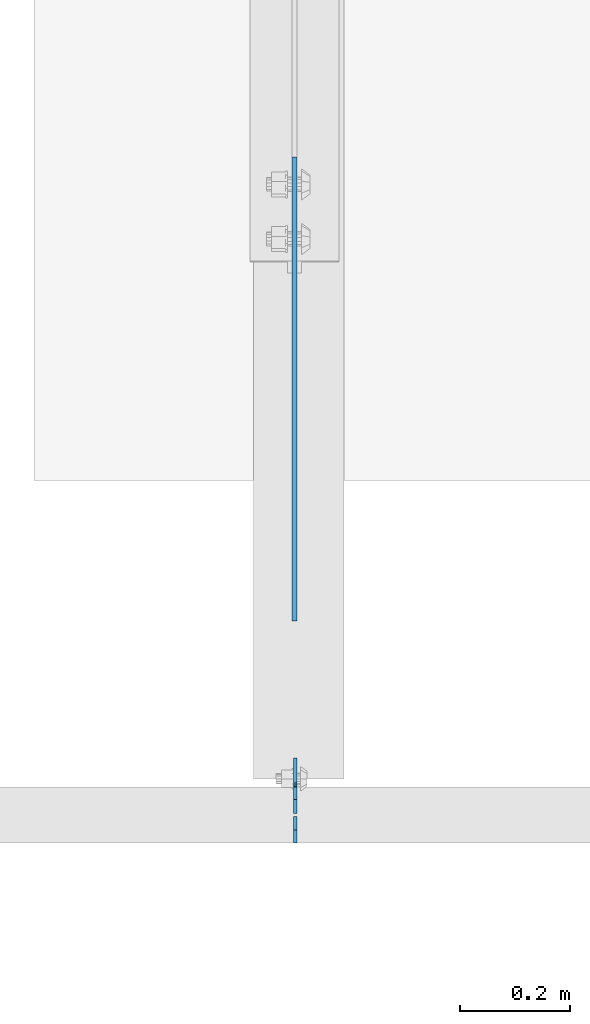
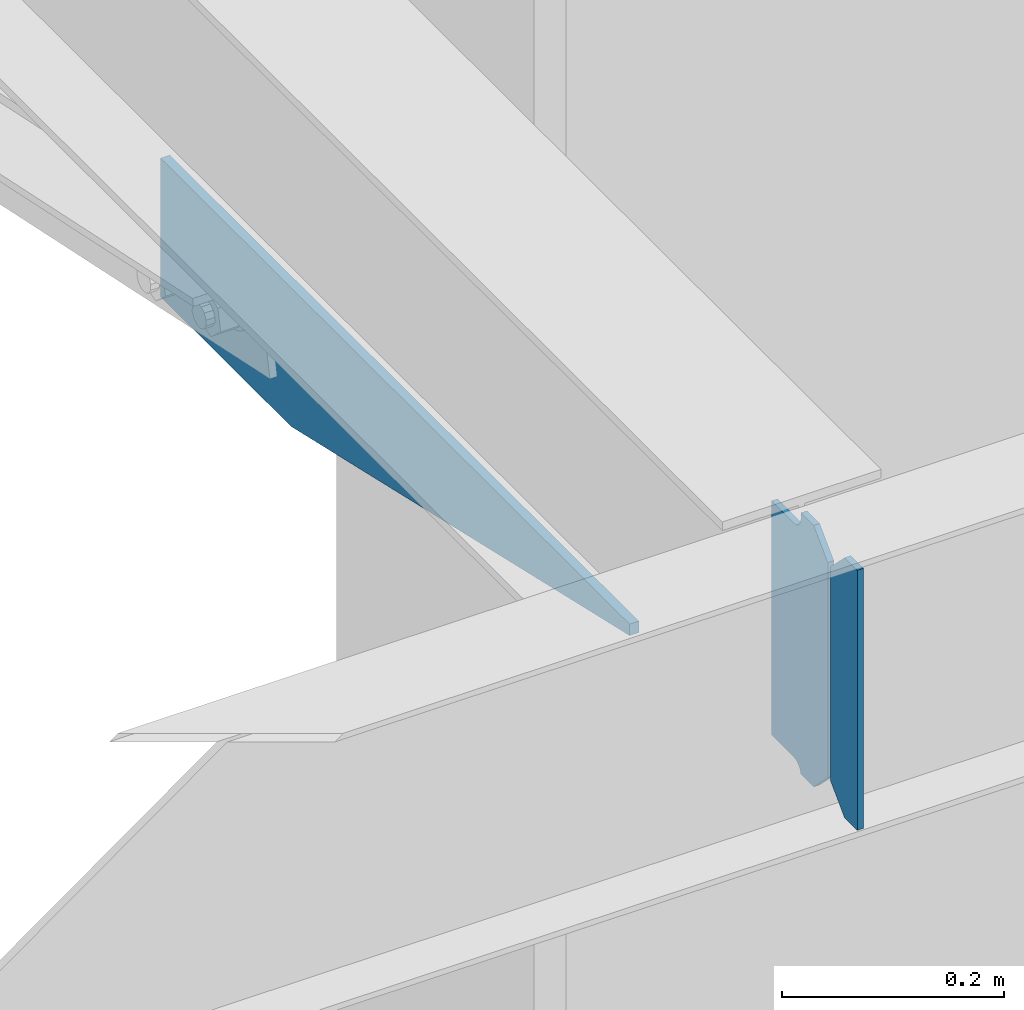
# One storey, part 1604 of 1763: 3 plates, 2 elements without a shape of their own.
"""IFC2X3 building model written with IfcOpenShell, lengths in millimetres."""

import ifcopenshell
import ifcopenshell.guid

model = None  # the IFC model being written
_history = None  # IfcOwnerHistory: only IFC2X3 demands one
_inside = {}  # id of a spatial element -> (the spatial element, [elements in it])
_under = {}  # id of a project, library or spatial element -> (it, [spatial elements below it])
_declared = {}  # id of a project -> (the project, [libraries it declares])
_typed = {}  # id of a type object -> (the type object, [elements of that type])
_made_of = {}  # id of a material, layer set ... -> (it, [elements and type objects made of it])


def new_model(schema):
    """Start an empty IFC model of exactly this schema.

    Asked for "IFC4X3", IfcOpenShell would pick the latest addendum, in which some entities
    have other attributes; the version numbers below select the first issue.
    IFC2X3 requires an IfcOwnerHistory on every rooted entity: one is made here for all.
    """
    global model, _history
    if schema == "IFC4X3":
        model = ifcopenshell.file(schema_version=(4, 3, 0, 0))
    else:
        model = ifcopenshell.file(schema=schema)
    _inside.clear()
    _under.clear()
    _declared.clear()
    _typed.clear()
    _made_of.clear()
    _history = None
    if model.schema == "IFC2X3":
        org = make("IfcOrganization", Name="unknown")
        user = make(
            "IfcPersonAndOrganization",
            ThePerson=make("IfcPerson", FamilyName="unknown"),
            TheOrganization=org,
        )
        app = make(
            "IfcApplication",
            ApplicationDeveloper=org,
            Version="unknown",
            ApplicationFullName="unknown",
            ApplicationIdentifier="unknown",
        )
        _history = make(
            "IfcOwnerHistory",
            OwningUser=user,
            OwningApplication=app,
            ChangeAction="ADDED",
            CreationDate=0,
        )
    return model


def make(cls, **values):
    """One entity of the class cls with the attributes given. An attribute that is None is left unset."""
    return model.create_entity(
        cls, **{name: value for name, value in values.items() if value is not None}
    )


def rooted(cls, **values):
    """An entity with a GlobalId (a new one), such as an element, a storey or a relation."""
    return make(cls, GlobalId=ifcopenshell.guid.new(), OwnerHistory=_history, **values)


def si_unit(unit_type, name, prefix=None):
    """IfcSIUnit, for example si_unit("LENGTHUNIT", "METRE", prefix="MILLI")."""
    return make("IfcSIUnit", UnitType=unit_type, Prefix=prefix, Name=name)


def assignment(units):
    """IfcUnitAssignment: the units of a project."""
    return None if units is None else make("IfcUnitAssignment", Units=units)


def point(xyz):
    """IfcCartesianPoint."""
    return None if xyz is None else make("IfcCartesianPoint", Coordinates=xyz)


def direction(xyz):
    """IfcDirection."""
    return None if xyz is None else make("IfcDirection", DirectionRatios=xyz)


def frame(location, z_axis=None, x_axis=None):
    """IfcAxis2Placement3D, a coordinate frame: its origin and axes. An axis left out is left unset."""
    return make(
        "IfcAxis2Placement3D",
        Location=point(location),
        Axis=direction(z_axis),
        RefDirection=direction(x_axis),
    )


def origin_with_axes():
    """The frame at (0, 0, 0) with the z axis (0, 0, 1) and the x axis (1, 0, 0) written out."""
    return frame((0.0, 0.0, 0.0), z_axis=(0.0, 0.0, 1.0), x_axis=(1.0, 0.0, 0.0))


def place(relative_to, where):
    """IfcLocalPlacement: puts the frame where relative to a parent placement (None: the world)."""
    return make(
        "IfcLocalPlacement", PlacementRelTo=relative_to, RelativePlacement=where
    )


def context(
    kind, dimensions, precision=None, world=None, true_north=None, identifier=None
):
    """IfcGeometricRepresentationContext, for example the 3D "Model" context."""
    return make(
        "IfcGeometricRepresentationContext",
        ContextIdentifier=identifier,
        ContextType=kind,
        CoordinateSpaceDimension=dimensions,
        Precision=precision,
        WorldCoordinateSystem=world,
        TrueNorth=true_north,
    )


def subcontext(parent, identifier, kind, view, scale=None):
    """IfcGeometricRepresentationSubContext, for example "Body" below "Model"."""
    return make(
        "IfcGeometricRepresentationSubContext",
        ContextIdentifier=identifier,
        ContextType=kind,
        ParentContext=parent,
        TargetScale=scale,
        TargetView=view,
    )


def project(units=None, contexts=None):
    """IfcProject with its units and contexts."""
    return rooted(
        "IfcProject",
        Name="project",
        RepresentationContexts=contexts,
        UnitsInContext=assignment(units),
    )


def spatial(cls, under=None, at=None, **own):
    """A site, building, storey or space (cls), placed at a placement, below another one or the project."""
    s = rooted(cls, ObjectPlacement=at, **own)
    if under is not None:
        _under.setdefault(under.id(), (under, []))[1].append(s)
    return s


def faces_of(points, faces, orient=None, outer=None):
    """IfcFace entities. A face is a list of loops; a loop is a list of indices into points, from 0.

    orient and outer hold one flag for each loop. By default every Orientation is true, the
    first loop of a face is its IfcFaceOuterBound and the others are IfcFaceBound.
    """
    made = []
    for i, loops in enumerate(faces):
        bounds = []
        for j, loop in enumerate(loops):
            is_outer = j == 0 if outer is None else outer[i][j]
            bounds.append(
                make(
                    "IfcFaceOuterBound" if is_outer else "IfcFaceBound",
                    Bound=make("IfcPolyLoop", Polygon=[points[k] for k in loop]),
                    Orientation=True if orient is None else orient[i][j],
                )
            )
        made.append(make("IfcFace", Bounds=bounds))
    return made


def faceted_brep(points, faces, orient=None, outer=None, voids=None):
    """IfcFacetedBrep: a solid bounded by flat faces; with voids (closed shells), ...WithVoids."""
    shared = [point(p) for p in points]
    hull = make("IfcClosedShell", CfsFaces=faces_of(shared, faces, orient, outer))
    if voids is None:
        return make("IfcFacetedBrep", Outer=hull)
    return make(
        "IfcFacetedBrepWithVoids",
        Outer=hull,
        Voids=[
            make(cls, CfsFaces=faces_of(shared, fs, o, b)) for cls, fs, o, b in voids
        ],
    )


def shape(context_of_items, identifier, shape_type, items):
    """IfcShapeRepresentation: the items that make up one representation, for example the "Body"."""
    return make(
        "IfcShapeRepresentation",
        ContextOfItems=context_of_items,
        RepresentationIdentifier=identifier,
        RepresentationType=shape_type,
        Items=items,
    )


def material(Name=None, Category=None):
    """IfcMaterial."""
    return make("IfcMaterial", Name=Name, Category=Category)


def made_of(thing, what):
    """Note that an element or type object is made of a material, layer set ...; save() writes the relation."""
    if what is not None:
        _made_of.setdefault(what.id(), (what, []))[1].append(thing)
    return thing


def type_object(cls, material=None, **own):
    """A type object (cls), such as IfcWallType, which elements share."""
    return made_of(rooted(cls, **own), material)


def element(
    cls,
    number,
    at=None,
    inside=None,
    cuts=None,
    type_object=None,
    material=None,
    context=None,
    identifier="Body",
    shape_type=None,
    held_by="IfcProductDefinitionShape",
    body=None,
    shapes=None,
    **own,
):
    """One element of the class cls, such as IfcWall. Its Tag is "e" and its number.

    at: its placement. inside: the storey or other place that contains it. cuts: it is an
    opening in that element (IfcRelVoidsElement). A single representation is given by context,
    identifier, shape_type and body (its items); several are given by shapes. held_by: the class
    of the entity that holds the representations. save() writes the other relations.
    """
    e = rooted(cls, Tag="e%d" % number, ObjectPlacement=at, **own)
    if body is not None:
        shapes = [shape(context, identifier, shape_type, body)]
    if shapes is not None:
        e.Representation = make(held_by, Representations=shapes)
    if inside is not None:
        _inside.setdefault(inside.id(), (inside, []))[1].append(e)
    if cuts is not None:
        rooted(
            "IfcRelVoidsElement", RelatingBuildingElement=cuts, RelatedOpeningElement=e
        )
    if type_object is not None:
        _typed.setdefault(type_object.id(), (type_object, []))[1].append(e)
    return made_of(e, material)


def aggregate(whole, parts):
    """IfcRelAggregates: a whole, such as a stair, and the parts it consists of."""
    return rooted("IfcRelAggregates", RelatingObject=whole, RelatedObjects=parts)


def save(model, path):
    """Write the relations noted so far, then the file.

    IfcRelAggregates (storeys below a building ...), IfcRelContainedInSpatialStructure (elements
    in a storey), IfcRelDefinesByType, IfcRelAssociatesMaterial and IfcRelDeclares: one each for
    every whole, place, type object, material and project.
    """
    for whole, parts in _under.values():
        aggregate(whole, parts)
    for where, things in _inside.values():
        rooted(
            "IfcRelContainedInSpatialStructure",
            RelatedElements=things,
            RelatingStructure=where,
        )
    for kind, things in _typed.values():
        rooted("IfcRelDefinesByType", RelatedObjects=things, RelatingType=kind)
    for what, things in _made_of.values():
        rooted("IfcRelAssociatesMaterial", RelatedObjects=things, RelatingMaterial=what)
    for by, libraries in _declared.values():
        rooted("IfcRelDeclares", RelatingContext=by, RelatedDefinitions=libraries)
    model.write(path)


model = new_model("IFC2X3")

# Units and contexts
model_context = context("Model", 3, precision=1e-05, world=origin_with_axes())
body_context = subcontext(model_context, "Body", "Model", "MODEL_VIEW")
ifc_project = project(units=[si_unit("LENGTHUNIT", "METRE", prefix="MILLI"), si_unit("AREAUNIT", "SQUARE_METRE"), si_unit("VOLUMEUNIT", "CUBIC_METRE"), si_unit("MASSUNIT", "GRAM", prefix="KILO"), si_unit("TIMEUNIT", "SECOND"), si_unit("PLANEANGLEUNIT", "RADIAN"), si_unit("SOLIDANGLEUNIT", "STERADIAN"), si_unit("THERMODYNAMICTEMPERATUREUNIT", "DEGREE_CELSIUS"), si_unit("LUMINOUSINTENSITYUNIT", "LUMEN")], contexts=[model_context])

# Site, building, storey
site_placement = place(None, origin_with_axes())
site = spatial("IfcSite", under=ifc_project, at=site_placement, CompositionType="ELEMENT")
building_placement = place(site_placement, origin_with_axes())
building = spatial("IfcBuilding", under=site, at=building_placement, Name="Undefined", CompositionType="ELEMENT")
storey_placement = place(building_placement, origin_with_axes())
storey = spatial("IfcBuildingStorey", under=building, at=storey_placement, Name="Undefined", CompositionType="ELEMENT", Elevation=0.0)

# Assembly, plate
assembly_1_placement = place(storey_placement, origin_with_axes())
assembly_1 = element("IfcElementAssembly", 1, at=assembly_1_placement, inside=storey, Name="BEAM", AssemblyPlace="NOTDEFINED", PredefinedType="RIGID_FRAME")
ifc_material = material(Name="STEEL/A36")
plate_type_1 = type_object("IfcPlateType", PredefinedType="NOTDEFINED")
plate_1_placement = place(assembly_1_placement, frame((-73845.1747736984, 50880.5595338104, 4883.15), z_axis=(0.0, -1.0, 0.0), x_axis=(0.0, 0.0, -1.0)))
plate_1 = element("IfcPlate", 2, at=plate_1_placement, type_object=plate_type_1, material=ifc_material, Name="PLATE", context=body_context, shape_type="Brep", body=[
    faceted_brep([(0.0, -4.76249999999982, 0.0), (0.0, -4.76249999999709, 844.603210449219), (0.0, 4.76249999999709, 844.603210449219), (0.0, 4.76249999999982, 0.0), (12.6999998092651, -4.76249999999709, 844.603210449219), (12.6999998092651, 4.76249999999709, 844.603210449219), (152.399993896484, -4.76249999999709, 235.00325012207), (152.399993896484, 4.76249999999709, 235.00325012207), (152.400009155272, -4.76249999948777, 5.45696821063757e-12), (152.400009155273, 4.76250000051368, 3.63797880709171e-12)], [[[0, 1, 2, 3]], [[1, 4, 5, 2]], [[4, 6, 7, 5]], [[6, 8, 9, 7]], [[8, 0, 3, 9]], [[5, 7, 9, 3, 2]], [[8, 6, 4, 1, 0]]]),
])
aggregate(assembly_1, [plate_1])

# Assembly, plates
assembly_2_placement = place(storey_placement, origin_with_axes())
assembly_2 = element("IfcElementAssembly", 3, at=assembly_2_placement, inside=storey, Name="BEAM", AssemblyPlace="NOTDEFINED", PredefinedType="RIGID_FRAME")
plate_type_2 = type_object("IfcPlateType", PredefinedType="NOTDEFINED")
plate_2_placement = place(assembly_2_placement, frame((-73843.587273746, 49684.78125, 4900.6125), z_axis=(0.0, 0.0, 1.0), x_axis=(0.0, 1.0, 0.0)))
plate_2 = element("IfcPlate", 4, at=plate_2_placement, type_object=plate_type_2, material=ifc_material, Name="PLATE", context=body_context, shape_type="Brep", body=[
    faceted_brep([(48.7345236062902, -3.17500000000291, 0.0), (48.7345236062902, 3.17500000000291, 0.0), (49.3854800386544, 3.17500000000291, 3.27257877585271), (49.3854800386544, -3.17500000000291, 3.27257877585271), (52.1384942519726, 3.17500000000291, 7.39275539271512), (52.1384942519726, -3.17500000000291, 7.39275539271512), (56.2586711318072, 3.17500000000291, 10.1457692124714), (56.2586711318072, -3.17500000000291, 10.1457692124714), (61.1187510223899, 3.17500000000291, 11.1124987868779), (61.1187510223899, -3.17500000000291, 11.1124987868779), (101.599998474121, -3.17500000000291, 11.1124949200548), (101.599998474121, 3.17500000000291, 11.1124949200548), (25.3999996184939, -3.17499999996653, 1.2732925824821e-11), (0.0, -3.17499999987194, 25.4000000001051), (0.0, 3.17500000014843, 25.4000000001197), (25.3999996185303, 3.17499995230901, 0.0), (0.0, -3.17500000000291, 261.937494277954), (0.0, 3.17500000000291, 261.937494277954), (25.3999996185303, -3.17500000000291, 287.337493896484), (25.3999996185303, 3.17500000000291, 287.337493896484), (48.4187500000044, -3.17500000000291, 287.337493896484), (48.4187500000044, 3.17500000000291, 287.337493896484), (48.4187500000044, -3.17500000000291, 280.987500572204), (48.4187500000044, 3.17500000000291, 280.987500572204), (49.3854799225956, -3.17500000000291, 276.127421054159), (49.3854799225956, 3.17500000000291, 276.127421054159), (52.1384938230694, -3.17500000000291, 272.007244586005), (52.1384938230694, 3.17500000000291, 272.007244586005), (56.2586702912231, -3.17500000000291, 269.254230685527), (56.2586702912231, 3.17500000000291, 269.254230685527), (61.1187498092695, -3.17500000000291, 268.287500762939), (61.1187498092695, 3.17500000000291, 268.287500762939), (101.599998474121, -3.17500000000291, 268.287500762939), (101.599998474121, 3.17500000000291, 268.287500762939)], [[[0, 1, 2, 3]], [[3, 2, 4, 5]], [[5, 4, 6, 7]], [[7, 6, 8, 9]], [[10, 9, 8, 11]], [[12, 13, 14, 15]], [[13, 16, 17, 14]], [[16, 18, 19, 17]], [[19, 18, 20, 21]], [[20, 22, 23, 21]], [[24, 25, 23, 22]], [[26, 27, 25, 24]], [[28, 29, 27, 26]], [[30, 31, 29, 28]], [[32, 33, 31, 30]], [[33, 32, 10, 11]], [[6, 4, 2, 1, 15, 14, 17, 19, 21, 23, 25, 27, 29, 31, 33, 11, 8]], [[12, 15, 1, 0]], [[32, 30, 28, 26, 24, 22, 20, 18, 16, 13, 12, 0, 3, 5, 7, 9, 10]]]),
])
plate_type_3 = type_object("IfcPlateType", PredefinedType="NOTDEFINED")
plate_3_placement = place(assembly_2_placement, frame((-73843.587273746, 49680.01875, 4900.6125), z_axis=(0.0, 0.0, 1.0), x_axis=(0.0, -1.0, 0.0)))
plate_3 = element("IfcPlate", 5, at=plate_3_placement, type_object=plate_type_3, material=ifc_material, Name="PLATE", context=body_context, shape_type="Brep", body=[
    faceted_brep([(0.0, -3.17499999987194, 25.4000000001051), (0.0, -3.17500000000291, 260.35000038147), (0.0, 3.17500000000291, 260.35000038147), (0.0, 3.17500000014843, 25.4000000001197), (25.3999996185303, -3.17500000000291, 285.75), (25.3999996185303, 3.17500000000291, 285.75), (48.4187507629395, -3.17500000000291, 285.75), (48.4187507629395, 3.17500000000291, 285.75), (48.4187507629395, -3.17500000000291, 0.0), (48.4187507629395, 3.17500000000291, 0.0), (25.3999996184939, -3.17499999996653, 1.2732925824821e-11), (25.3999996185303, 3.17499995230901, 0.0)], [[[0, 1, 2, 3]], [[1, 4, 5, 2]], [[4, 6, 7, 5]], [[6, 8, 9, 7]], [[8, 10, 11, 9]], [[10, 0, 3, 11]], [[5, 7, 9, 11, 3, 2]], [[10, 8, 6, 4, 1, 0]]]),
])
aggregate(assembly_2, [plate_3, plate_2])

save(model, "model.ifc")
